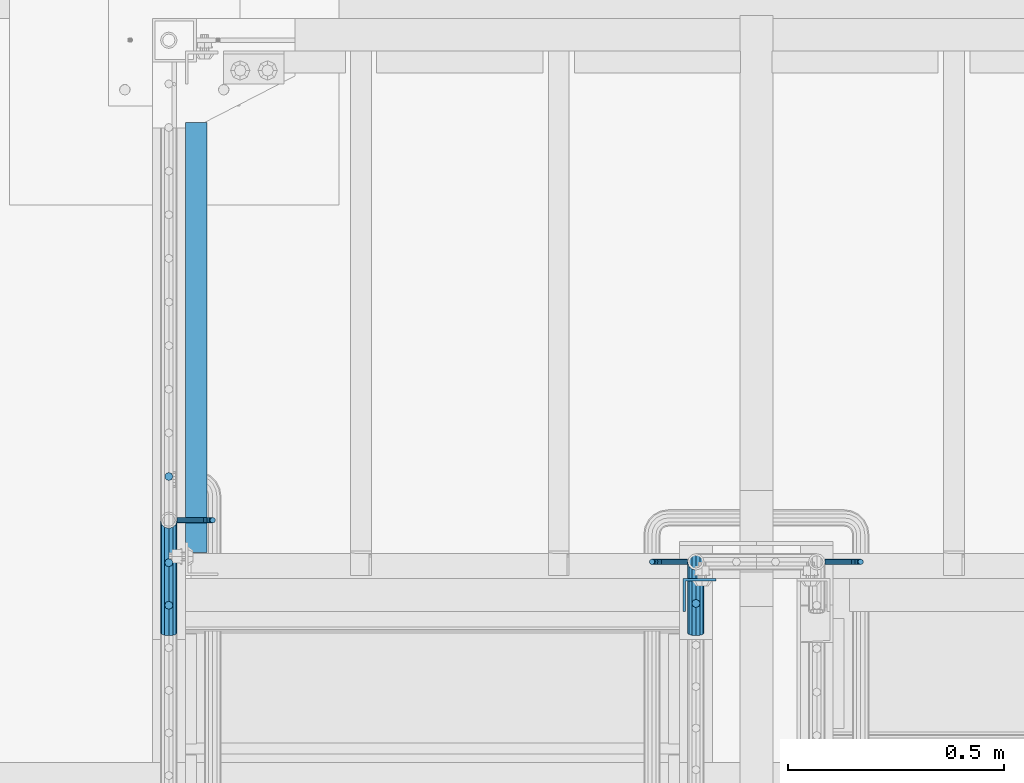
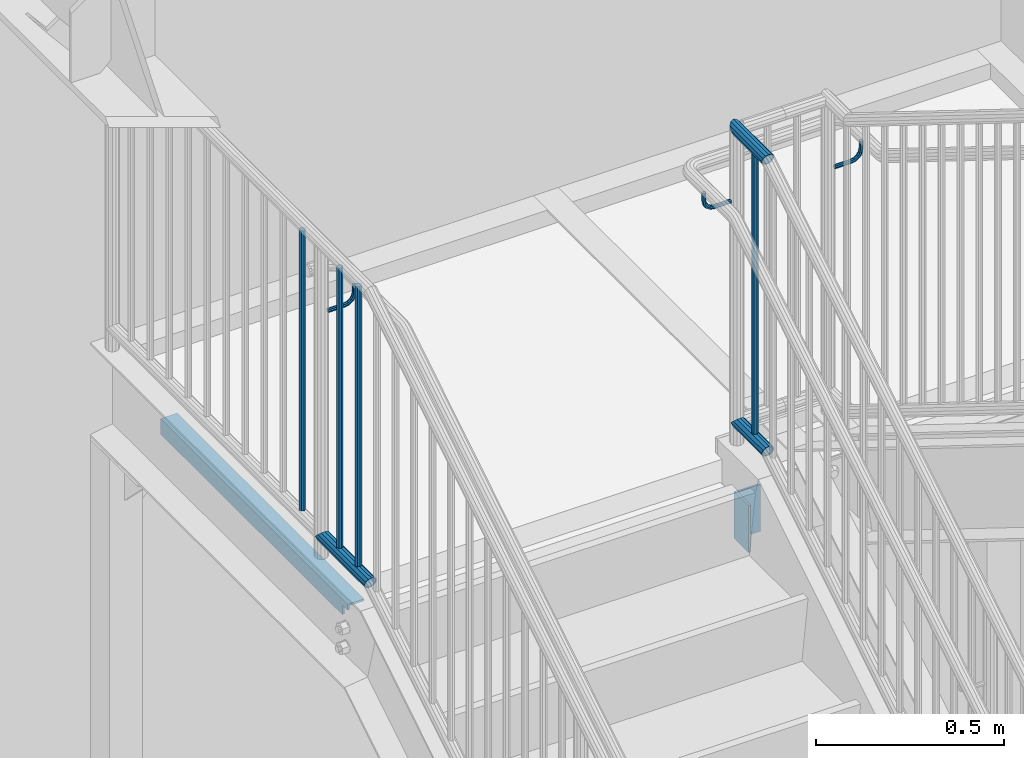
# One storey, part 1273 of 1763: 12 beams, 4 elements without a shape of their own.
"""IFC2X3 building model written with IfcOpenShell, lengths in millimetres."""

from ifc_helpers import new_model, si_unit, frame, origin_with_axes, place, context, subcontext, project, spatial, faceted_brep, material, type_object, element, aggregate, save


model = new_model("IFC2X3")

# Units and contexts
model_context = context("Model", 3, precision=1e-05, world=origin_with_axes())
body_context = subcontext(model_context, "Body", "Model", "MODEL_VIEW")
ifc_project = project(units=[si_unit("LENGTHUNIT", "METRE", prefix="MILLI"), si_unit("AREAUNIT", "SQUARE_METRE"), si_unit("VOLUMEUNIT", "CUBIC_METRE"), si_unit("MASSUNIT", "GRAM", prefix="KILO"), si_unit("TIMEUNIT", "SECOND"), si_unit("PLANEANGLEUNIT", "RADIAN"), si_unit("SOLIDANGLEUNIT", "STERADIAN"), si_unit("THERMODYNAMICTEMPERATUREUNIT", "DEGREE_CELSIUS"), si_unit("LUMINOUSINTENSITYUNIT", "LUMEN")], contexts=[model_context])

# Site, building, storey
site_placement = place(None, origin_with_axes())
site = spatial("IfcSite", under=ifc_project, at=site_placement, CompositionType="ELEMENT")
building_placement = place(site_placement, origin_with_axes())
building = spatial("IfcBuilding", under=site, at=building_placement, Name="Undefined", CompositionType="ELEMENT")
storey_placement = place(building_placement, origin_with_axes())
storey = spatial("IfcBuildingStorey", under=building, at=storey_placement, Name="Undefined", CompositionType="ELEMENT", Elevation=0.0)

# Assembly, beams
assembly_1_placement = place(storey_placement, origin_with_axes())
assembly_1 = element("IfcElementAssembly", 1, at=assembly_1_placement, inside=storey, Name="RAIL", AssemblyPlace="NOTDEFINED", PredefinedType="RIGID_FRAME")
ifc_material_1 = material(Name="STEEL/A513")
beam_type_1 = type_object("IfcBeamType", PredefinedType="NOTDEFINED")
beam_1_placement = place(assembly_1_placement, frame((-85559.3372736932, 35928.2999984601, 2852.7375000151), z_axis=(0.0, 0.0, 1.0), x_axis=(0.0, 1.0, 0.0)))
beam_1 = element("IfcBeam", 2, at=beam_1_placement, type_object=beam_type_1, material=ifc_material_1, Name="RAIL", context=body_context, shape_type="Brep", body=[
    faceted_brep([(148.602217967113, -9.52499999999418, 16.4977839420935), (148.602217967113, -9.52499999999418, 11.4667123799554), (148.108789529251, -7.68349999999919, 13.3082123799554), (146.050001909207, 0.0, 15.3670000000002), (146.050001909207, 0.0, 19.0500000000002), (148.108789529251, 7.68349999999919, 13.3082123799554), (148.602217967113, 9.52499999999418, 11.4667123799554), (148.602217967113, 9.52499999999418, 16.4977839420935), (165.10000190921, 19.0500000000029, 0.0), (155.575001909208, 16.4977839420899, 9.52500000000009), (155.575001909208, 16.4977839420899, -9.52500000000009), (152.385430347073, 13.3082123799541, 7.68350000000009), (154.444217967117, 15.3669999999984, 0.0), (152.385430347073, 13.3082123799541, -7.68350000000009), (148.602217967113, 9.52499999999418, -11.4667123799554), (148.602217967113, 9.52499999999418, -16.4977839420935), (148.108789529251, 7.68349999999919, -13.3082123799554), (146.050001909207, 0.0, -15.3670000000002), (146.050001909207, 0.0, -19.0500000000002), (148.602217967113, -9.52499999999418, -11.4667123799554), (148.602217967113, -9.52499999999418, -16.4977839420935), (148.108789529251, -7.68349999999919, -13.3082123799554), (165.10000190921, -19.0500000000029, 0.0), (155.575001909208, -16.4977839420899, -9.52500000000009), (155.575001909208, -16.4977839420899, 9.52500000000009), (152.385430347073, -13.3082123799541, -7.68350000000009), (154.444217967117, -15.3669999999984, 0.0), (152.385430347073, -13.3082123799541, 7.68350000000009), (2.71516178591992, -16.4977839420899, -9.52500000000009), (4.70279812946683, -9.52499999999418, -16.4977839420935), (5.43032352469163, 0.0, -19.0500000000002), (4.70279812946683, 9.52499999999418, -16.4977839420935), (2.71516178591992, 16.4977839420899, -9.52500000000009), (0.0, 19.0500000000029, 0.0), (-2.71516169163806, 16.4977839420899, 9.52500000000009), (-4.70279803518497, 9.52499999999418, 16.4977839420935), (-5.43032343040977, 0.0, 19.0500000000002), (-4.70279803518497, -9.52499999999418, 16.4977839420935), (-2.71516169163806, -16.4977839420899, 9.52500000000009), (0.0, -19.0500000000029, 0.0), (2.19023051641852, -13.3082123799541, -7.68350000000009), (3.79359050021594, -7.68349999999919, -13.3082123799554), (4.38046098569612, 0.0, -15.3670000000002), (3.79359050021594, 7.68349999999919, -13.3082123799554), (2.19023051641852, 13.3082123799541, -7.68350000000009), (4.71409293822944e-08, 15.3669999999984, 0.0), (-2.19023042213666, 13.3082123799541, 7.68350000000009), (-3.79359040593408, 7.68349999999919, 13.3082123799554), (-4.38046089142154, 0.0, 15.3670000000002), (-3.79359040593408, -7.68349999999919, 13.3082123799554), (-2.19023042213666, -13.3082123799541, 7.68350000000009), (4.71409293822944e-08, -15.3669999999984, 0.0)], [[[0, 1, 2, 3, 4]], [[4, 3, 5, 6, 7]], [[8, 9, 10]], [[7, 6, 11, 12, 13, 14, 15, 10, 9]], [[16, 17, 18, 15, 14]], [[19, 20, 18, 17, 21]], [[22, 23, 24]], [[24, 23, 20, 19, 25, 26, 27, 1, 0]], [[28, 29, 20, 23]], [[29, 30, 18, 20]], [[30, 31, 15, 18]], [[31, 32, 10, 15]], [[32, 33, 8, 10]], [[33, 34, 9, 8]], [[34, 35, 7, 9]], [[35, 36, 4, 7]], [[36, 37, 0, 4]], [[37, 38, 24, 0]], [[38, 39, 22, 24]], [[39, 28, 23, 22]], [[38, 37, 36, 35, 34, 33, 32, 31, 30, 29, 28, 39], [40, 41, 42, 43, 44, 45, 46, 47, 48, 49, 50, 51]], [[40, 51, 26, 25]], [[21, 41, 40, 25, 19]], [[42, 41, 21, 17]], [[43, 42, 17, 16]], [[44, 43, 16, 14, 13]], [[45, 44, 13, 12]], [[46, 45, 12, 11]], [[5, 47, 46, 11, 6]], [[48, 47, 5, 3]], [[49, 48, 3, 2]], [[50, 49, 2, 1, 27]], [[51, 50, 27, 26]]]),
])
beam_2_placement = place(assembly_1_placement, frame((-85559.3372736932, 36093.4000003693, 3798.8875000151), z_axis=(0.0, 0.0, -1.0), x_axis=(0.0, -1.0, 0.0)))
beam_2 = element("IfcBeam", 3, at=beam_2_placement, type_object=beam_type_1, material=ifc_material_1, Name="RAIL", context=body_context, shape_type="Brep", body=[
    faceted_brep([(4.71409293822944e-08, -15.3669999999984, 0.0), (7.68350000096689, -13.3082123799541, 7.68350000000009), (162.909771405139, -13.3082123799541, 7.68350000000009), (165.100001874416, -15.3669999999984, 0.0), (13.3082123809218, -7.68349999999919, 13.3082123799554), (161.306411421341, -7.68349999999919, 13.3082123799554), (15.3670000009661, 0.0, 15.3670000000002), (160.719540935861, 0.0, 15.3670000000002), (13.3082123809218, 7.68349999999919, 13.3082123799554), (161.306411421341, 7.68349999999919, 13.3082123799554), (7.68350000096689, 13.3082123799541, 7.68350000000009), (162.909771405139, 13.3082123799541, 7.68350000000009), (4.71409293822944e-08, 15.3669999999984, 0.0), (165.100001874416, 15.3669999999984, 0.0), (-7.68349999903876, 13.3082123799541, -7.68350000000009), (167.290232343701, 13.3082123799541, -7.68350000000009), (-13.3082123789936, 7.68349999999919, -13.3082123799554), (168.893592327498, 7.68349999999919, -13.3082123799554), (-15.3669999990379, 0.0, -15.3670000000002), (169.480462812979, 0.0, -15.3670000000002), (-13.3082123789936, -7.68349999999919, -13.3082123799554), (168.893592327498, -7.68349999999919, -13.3082123799554), (-7.68349999903876, -13.3082123799541, -7.68350000000009), (167.290232343701, -13.3082123799541, -7.68350000000009), (0.0, -19.0500000000029, 0.0), (-9.52499999903375, -16.4977839420899, -9.52500000000009), (167.815163613195, -16.4977839420899, -9.52500000000009), (165.10000190921, -19.0500000000029, 0.0), (-16.4977839411295, -9.52499999999418, -16.4977839420935), (169.802799956749, -9.52499999999418, -16.4977839420935), (-19.0499999990352, 0.0, -19.0500000000002), (170.530325351974, 0.0, -19.0500000000002), (-16.4977839411295, 9.52499999999418, -16.4977839420935), (169.802799956749, 9.52499999999418, -16.4977839420935), (-9.52499999903375, 16.4977839420899, -9.52500000000009), (167.815163613195, 16.4977839420899, -9.52500000000009), (0.0, 19.0500000000029, 0.0), (165.10000190921, 19.0500000000029, 0.0), (9.52500000096188, 16.4977839420899, 9.52500000000009), (162.384840135644, 16.4977839420899, 9.52500000000009), (16.4977839430576, 9.52499999999418, 16.4977839420935), (160.39720379209, 9.52499999999418, 16.4977839420935), (19.0500000009633, 0.0, 19.0500000000002), (159.669678396865, 0.0, 19.0500000000002), (16.4977839430576, -9.52499999999418, 16.4977839420935), (160.39720379209, -9.52499999999418, 16.4977839420935), (9.52500000096188, -16.4977839420899, 9.52500000000009), (162.384840135644, -16.4977839420899, 9.52500000000009)], [[[0, 1, 2, 3]], [[1, 4, 5, 2]], [[4, 6, 7, 5]], [[6, 8, 9, 7]], [[8, 10, 11, 9]], [[10, 12, 13, 11]], [[12, 14, 15, 13]], [[14, 16, 17, 15]], [[16, 18, 19, 17]], [[18, 20, 21, 19]], [[20, 22, 23, 21]], [[22, 0, 3, 23]], [[24, 25, 26, 27]], [[25, 28, 29, 26]], [[28, 30, 31, 29]], [[30, 32, 33, 31]], [[32, 34, 35, 33]], [[34, 36, 37, 35]], [[36, 38, 39, 37]], [[38, 40, 41, 39]], [[40, 42, 43, 41]], [[42, 44, 45, 43]], [[44, 46, 47, 45]], [[46, 24, 27, 47]], [[29, 31, 33, 35, 37, 39, 41, 43, 45, 47, 27, 26], [5, 7, 9, 11, 13, 15, 17, 19, 21, 23, 3, 2]], [[46, 44, 42, 40, 38, 36, 34, 32, 30, 28, 25, 24], [22, 20, 18, 16, 14, 12, 10, 8, 6, 4, 1, 0]]]),
])

# Assembly, beam
assembly_2_placement = place(storey_placement, origin_with_axes())
assembly_2 = element("IfcElementAssembly", 4, at=assembly_2_placement, inside=storey, Name="RAIL", AssemblyPlace="NOTDEFINED", PredefinedType="RIGID_FRAME")
beam_3_placement = place(assembly_2_placement, frame((-86778.5372736909, 35928.2999984695, 2852.7375000151), z_axis=(0.0, 0.0, 1.0), x_axis=(0.0, 1.0, 0.0)))
beam_3 = element("IfcBeam", 5, at=beam_3_placement, type_object=beam_type_1, material=ifc_material_1, Name="RAIL", context=body_context, shape_type="Brep", body=[
    faceted_brep([(245.122217953525, -9.52499999999418, 16.4977839420935), (245.122217953525, -9.52499999782594, 11.4667123821237), (244.628789516246, -7.68349999999919, 13.3082123799554), (242.570001895619, 0.0, 15.3670000000002), (242.570001895619, 0.0, 19.0500000000002), (244.628789515089, 7.68349999999919, 13.3082123799554), (245.122217953525, 9.52500000216241, 11.4667123777872), (245.122217953525, 9.52499999999418, 16.4977839420935), (261.620001894713, 19.0500000000029, 0.0), (252.095001895621, 16.4977839420899, 9.52500000000009), (252.095001895621, 16.4977839420899, -9.52500000000009), (248.905430331317, 13.3082123799541, 7.68350000000009), (250.964217951361, 15.3669999999984, 0.0), (248.905430331317, 13.3082123799541, -7.68350000000009), (245.122217953525, 9.52500000216241, -11.4667123777872), (245.122217953525, 9.52499999999418, -16.4977839420935), (244.628789515089, 7.68349999999919, -13.3082123799554), (242.570001895619, 0.0, -15.3670000000002), (242.570001895619, 0.0, -19.0500000000002), (245.122217953525, -9.52499999782594, -11.4667123821237), (245.122217953525, -9.52499999999418, -16.4977839420935), (244.628789516246, -7.68349999999919, -13.3082123799554), (261.620001895622, -19.0499999978347, 0.0), (252.095001895621, -16.4977839420899, -9.52500000000009), (252.095001895621, -16.4977839420899, 9.52500000000009), (248.905430335653, -13.3082123799541, -7.68350000000009), (250.964217955698, -15.3669999999984, 0.0), (248.905430335653, -13.3082123799541, 7.68350000000009), (2.71516178591992, -16.4977839420899, -9.52500000000009), (4.70279812946683, -9.52499999999418, -16.4977839420935), (5.43032352469163, 0.0, -19.0500000000002), (4.70279812946683, 9.52499999999418, -16.4977839420935), (2.71516178591992, 16.4977839420899, -9.52500000000009), (0.0, 19.0500000000029, 0.0), (-2.71516169163806, 16.4977839420899, 9.52500000000009), (-4.70279803518497, 9.52499999999418, 16.4977839420935), (-5.43032343040977, 0.0, 19.0500000000002), (-4.70279803518497, -9.52499999999418, 16.4977839420935), (-2.71516169163806, -16.4977839420899, 9.52500000000009), (0.0, -19.0500000000029, 0.0), (2.19023051641852, -13.3082123799541, -7.68350000000009), (3.79359050021594, -7.68349999999919, -13.3082123799554), (4.38046098569612, 0.0, -15.3670000000002), (3.79359050021594, 7.68349999999919, -13.3082123799554), (2.19023051641852, 13.3082123799541, -7.68350000000009), (4.71409293822944e-08, 15.3669999999984, 0.0), (-2.19023042213666, 13.3082123799541, 7.68350000000009), (-3.79359040593408, 7.68349999999919, 13.3082123799554), (-4.38046089142154, 0.0, 15.3670000000002), (-3.79359040593408, -7.68349999999919, 13.3082123799554), (-2.19023042213666, -13.3082123799541, 7.68350000000009), (4.71409293822944e-08, -15.3669999999984, 0.0)], [[[0, 1, 2, 3, 4]], [[4, 3, 5, 6, 7]], [[8, 9, 10]], [[7, 6, 11, 12, 13, 14, 15, 10, 9]], [[16, 17, 18, 15, 14]], [[19, 20, 18, 17, 21]], [[22, 23, 24]], [[24, 23, 20, 19, 25, 26, 27, 1, 0]], [[28, 29, 20, 23]], [[29, 30, 18, 20]], [[30, 31, 15, 18]], [[31, 32, 10, 15]], [[32, 33, 8, 10]], [[33, 34, 9, 8]], [[34, 35, 7, 9]], [[35, 36, 4, 7]], [[36, 37, 0, 4]], [[37, 38, 24, 0]], [[38, 39, 22, 24]], [[39, 28, 23, 22]], [[38, 37, 36, 35, 34, 33, 32, 31, 30, 29, 28, 39], [40, 41, 42, 43, 44, 45, 46, 47, 48, 49, 50, 51]], [[40, 51, 26, 25]], [[21, 41, 40, 25, 19]], [[42, 41, 21, 17]], [[43, 42, 17, 16]], [[44, 43, 16, 14, 13]], [[45, 44, 13, 12]], [[46, 45, 12, 11]], [[5, 47, 46, 11, 6]], [[48, 47, 5, 3]], [[49, 48, 3, 2]], [[50, 49, 2, 1, 27]], [[51, 50, 27, 26]]]),
])

assembly_3_placement = place(storey_placement, origin_with_axes())
assembly_3 = element("IfcElementAssembly", 6, at=assembly_3_placement, inside=storey, Name="STRINGER", AssemblyPlace="NOTDEFINED", PredefinedType="RIGID_FRAME")
ifc_material_2 = material(Name="STEEL/A36")
beam_type_2 = type_object("IfcBeamType", Name="L2X2X1/4", PredefinedType="NOTDEFINED")
beam_4_placement = place(assembly_3_placement, frame((-86715.0372737858, 37109.3996371524, 2630.48876467044), z_axis=(0.0, -1.42259999993257e-05, -0.99999999989881), x_axis=(0.0, -0.99999999989881, 1.42259999987655e-05)))
beam_4 = element("IfcBeam", 7, at=beam_4_placement, type_object=beam_type_2, material=ifc_material_2, Name="ANGLE", ObjectType="L2X2X1/4", context=body_context, shape_type="Brep", body=[
    faceted_brep([(965.199274753315, 19.0500000000029, 25.3999999999201), (965.199726428713, 19.0500000000029, -6.33500439582212), (965.199726428713, 25.3999999999942, -6.33500439582212), (965.199274753315, 25.3999999999942, 25.3999999999201), (993.774727188727, 19.0500000000029, -6.33459788777009), (993.798162603365, 25.3999999999942, -6.33459788777054), (-1.45519152283669e-11, -25.4000000000015, -25.3999999999869), (-7.27595761418343e-12, -25.4000000000015, -19.0499999999956), (-7.27595761418343e-12, 19.0499999999993, -19.0499999999956), (1.45519152283669e-11, 19.0499999999993, 25.3999999999796), (1.45519152283669e-11, 25.4000000000015, 25.3999999999796), (-1.45519152283669e-11, 25.4000000000015, -25.3999999999869), (993.798162603474, 25.3999999999942, -25.3999999999182), (993.798162603474, -25.3999999999942, -25.3999999999182), (993.798162603453, -25.3999999999942, -19.0499999999197), (993.798162603453, 19.0500000000029, -19.0499999999197)], [[[0, 1, 2, 3]], [[4, 5, 2, 1]], [[6, 7, 8, 9, 10, 11]], [[6, 11, 12, 13]], [[7, 6, 13, 14]], [[8, 7, 14, 15]], [[0, 9, 8, 15, 4, 1]], [[10, 9, 0, 3]], [[12, 11, 10, 3, 2, 5]], [[15, 14, 13, 12, 5, 4]]]),
])

# Beam
beam_type_3 = type_object("IfcBeamType", PredefinedType="NOTDEFINED")
beam_5_placement = place(assembly_2_placement, frame((-86759.4872736811, 36189.9200003692, 3570.28760005298), z_axis=(0.0, -1.0, 0.0), x_axis=(1.0, 0.0, 0.0)))
beam_5 = element("IfcBeam", 8, at=beam_5_placement, type_object=beam_type_3, material=ifc_material_2, Name="RAIL", context=body_context, shape_type="Brep", body=[
    faceted_brep([(0.0, -6.34999999999491, 1.45519152283669e-11), (-1.13686837721616e-13, -4.49012806053361, -4.49012806058454), (50.8000030517578, -4.49012806053452, -4.49012806053361), (50.8000030517578, -6.35000000000036, 0.0), (0.0, 0.0, -6.34999990463257), (50.8000030517578, 0.0, -6.34999999999854), (0.0, 4.49012806054088, -4.49012806053452), (50.8000030517578, 4.49012806053452, -4.49012806053361), (0.0, 6.34999999999491, -2.91038304567337e-11), (50.8000030517578, 6.35000000000036, 0.0), (0.0, 4.49012806054088, 4.49012806053452), (50.8000030517578, 4.49012806053452, 4.49012806053361), (0.0, 0.0, 6.34999990463257), (50.8000030517578, 0.0, 6.34999999999854), (0.0, -4.49012806053361, 4.49012806055543), (50.8000030517578, -4.49012806053452, 4.49012806053361), (65.380241824867, -3.44981018867929, 0.0), (64.6684996473195, -1.73151257071549, 4.49012806053361), (62.9502020293439, 2.4168248427668, 6.34999999999854), (61.2319044113829, 6.5651622562491, 4.49012806053361), (60.5201622338354, 8.2834598742138, 0.0), (61.2319044113829, 6.5651622562491, -4.49012806053361), (62.9502020293439, 2.4168248427668, -6.34999999999854), (64.6684996473195, -1.73151257071549, -4.49012806053361), (76.425643354436, 6.12435969732724, -4.49012806053361), (77.7407714149595, 4.8092316367929, 0.0), (73.2506433544331, 9.29935969732742, -6.34999999999854), (70.0756433544302, 12.4743596973276, -4.49012806053361), (68.7605152938922, 13.7894877578619, 0.0), (70.0756433544302, 12.4743596973276, 4.49012806053361), (73.2506433544331, 9.29935969732742, 6.34999999999854), (76.425643354436, 6.12435969732724, 4.49012806053361), (84.2815156224679, 17.8815034044446, -4.49012806053361), (85.9998132404435, 17.1697612268908, 0.0), (80.1331782089983, 19.5998010224093, -6.34999999999854), (75.9848407955142, 21.3180986403731, -4.49012806053361), (74.2665431775386, 22.0298408179269, 0.0), (75.9848407955142, 21.3180986403731, 4.49012806053361), (80.1331782089983, 19.5998010224093, 6.34999999999854), (84.2815156224679, 17.8815034044446, 4.49012806053361), (87.0401311122987, 31.75, -4.49012806053361), (88.9000030517636, 31.75, 0.0), (82.5500030517578, 31.75, -6.34999999999854), (78.0598749912169, 31.75, -4.49012806053361), (76.200003051752, 31.75, 0.0), (78.0598749912169, 31.75, 4.49012806053361), (82.5500030517578, 31.75, 6.34999999999854), (87.0401311122987, 31.75, 4.49012806053361), (87.0401311122987, 57.1500015258789, -4.49012806053361), (88.9000030517636, 57.1500015258789, 0.0), (82.5500030517578, 57.1500015258789, -6.34999999999854), (78.0598749912169, 57.1500015258789, -4.49012806053361), (76.200003051752, 57.1500015258789, 0.0), (78.0598749912169, 57.1500015258789, 4.49012806053361), (82.5500030517578, 57.1500015258789, 6.34999999999854), (87.0401311122987, 57.1500015258789, 4.49012806053361)], [[[0, 1, 2, 3]], [[1, 4, 5, 2]], [[4, 6, 7, 5]], [[6, 8, 9, 7]], [[8, 10, 11, 9]], [[10, 12, 13, 11]], [[12, 14, 15, 13]], [[14, 0, 3, 15]], [[14, 12, 10, 8, 6, 4, 1, 0]], [[15, 3, 16, 17]], [[13, 15, 17, 18]], [[11, 13, 18, 19]], [[9, 11, 19, 20]], [[7, 9, 20, 21]], [[5, 7, 21, 22]], [[2, 5, 22, 23]], [[3, 2, 23, 16]], [[23, 24, 25, 16]], [[22, 26, 24, 23]], [[21, 27, 26, 22]], [[20, 28, 27, 21]], [[19, 29, 28, 20]], [[18, 30, 29, 19]], [[17, 31, 30, 18]], [[16, 25, 31, 17]], [[24, 32, 33, 25]], [[26, 34, 32, 24]], [[27, 35, 34, 26]], [[28, 36, 35, 27]], [[29, 37, 36, 28]], [[30, 38, 37, 29]], [[31, 39, 38, 30]], [[25, 33, 39, 31]], [[32, 40, 41, 33]], [[34, 42, 40, 32]], [[35, 43, 42, 34]], [[36, 44, 43, 35]], [[37, 45, 44, 36]], [[38, 46, 45, 37]], [[39, 47, 46, 38]], [[33, 41, 47, 39]], [[41, 40, 48, 49]], [[40, 42, 50, 48]], [[42, 43, 51, 50]], [[43, 44, 52, 51]], [[44, 45, 53, 52]], [[45, 46, 54, 53]], [[46, 47, 55, 54]], [[47, 41, 49, 55]], [[50, 51, 52, 53, 54, 55, 49, 48]]]),
])

# Assembly, beam
assembly_4_placement = place(storey_placement, origin_with_axes())
assembly_4 = element("IfcElementAssembly", 9, at=assembly_4_placement, inside=storey, Name="RAIL", AssemblyPlace="NOTDEFINED", PredefinedType="RIGID_FRAME")
beam_6_placement = place(assembly_4_placement, frame((-85260.8221005486, 36093.4000003674, 3570.28759880967), z_axis=(0.0, -1.0, 0.0), x_axis=(1.0, 0.0, 0.0)))
beam_6 = element("IfcBeam", 10, at=beam_6_placement, type_object=beam_type_3, material=ifc_material_2, Name="RAIL", context=body_context, shape_type="Brep", body=[
    faceted_brep([(0.0, -6.34999999999491, 1.45519152283669e-11), (-1.13686837721616e-13, -4.49012806053361, -4.49012806058454), (50.8000030517578, -4.49012806053452, -4.49012806053361), (50.8000030517578, -6.35000000000036, 0.0), (0.0, 0.0, -6.34999990463257), (50.8000030517578, 0.0, -6.34999999999854), (0.0, 4.49012806054088, -4.49012806053452), (50.8000030517578, 4.49012806053452, -4.49012806053361), (0.0, 6.34999999999491, -2.91038304567337e-11), (50.8000030517578, 6.35000000000036, 0.0), (0.0, 4.49012806054088, 4.49012806053452), (50.8000030517578, 4.49012806053452, 4.49012806053361), (0.0, 0.0, 6.34999990463257), (50.8000030517578, 0.0, 6.34999999999854), (0.0, -4.49012806053361, 4.49012806055543), (50.8000030517578, -4.49012806053452, 4.49012806053361), (65.380241824867, -3.44981018867929, 0.0), (64.6684996473195, -1.73151257071549, 4.49012806053361), (62.9502020293439, 2.4168248427668, 6.34999999999854), (61.2319044113829, 6.5651622562491, 4.49012806053361), (60.5201622338354, 8.2834598742138, 0.0), (61.2319044113829, 6.5651622562491, -4.49012806053361), (62.9502020293439, 2.4168248427668, -6.34999999999854), (64.6684996473195, -1.73151257071549, -4.49012806053361), (76.425643354436, 6.12435969732724, -4.49012806053361), (77.7407714149595, 4.8092316367929, 0.0), (73.2506433544331, 9.29935969732742, -6.34999999999854), (70.0756433544302, 12.4743596973276, -4.49012806053361), (68.7605152938922, 13.7894877578619, 0.0), (70.0756433544302, 12.4743596973276, 4.49012806053361), (73.2506433544331, 9.29935969732742, 6.34999999999854), (76.425643354436, 6.12435969732724, 4.49012806053361), (84.2815156224679, 17.8815034044446, -4.49012806053361), (85.9998132404435, 17.1697612268908, 0.0), (80.1331782089983, 19.5998010224093, -6.34999999999854), (75.9848407955142, 21.3180986403731, -4.49012806053361), (74.2665431775386, 22.0298408179269, 0.0), (75.9848407955142, 21.3180986403731, 4.49012806053361), (80.1331782089983, 19.5998010224093, 6.34999999999854), (84.2815156224679, 17.8815034044446, 4.49012806053361), (87.0401311122987, 31.75, -4.49012806053361), (88.9000030517636, 31.75, 0.0), (82.5500030517578, 31.75, -6.34999999999854), (78.0598749912169, 31.75, -4.49012806053361), (76.200003051752, 31.75, 0.0), (78.0598749912169, 31.75, 4.49012806053361), (82.5500030517578, 31.75, 6.34999999999854), (87.0401311122987, 31.75, 4.49012806053361), (87.0401311122987, 57.1500015258789, -4.49012806053361), (88.9000030517636, 57.1500015258789, 0.0), (82.5500030517578, 57.1500015258789, -6.34999999999854), (78.0598749912169, 57.1500015258789, -4.49012806053361), (76.200003051752, 57.1500015258789, 0.0), (78.0598749912169, 57.1500015258789, 4.49012806053361), (82.5500030517578, 57.1500015258789, 6.34999999999854), (87.0401311122987, 57.1500015258789, 4.49012806053361)], [[[0, 1, 2, 3]], [[1, 4, 5, 2]], [[4, 6, 7, 5]], [[6, 8, 9, 7]], [[8, 10, 11, 9]], [[10, 12, 13, 11]], [[12, 14, 15, 13]], [[14, 0, 3, 15]], [[14, 12, 10, 8, 6, 4, 1, 0]], [[15, 3, 16, 17]], [[13, 15, 17, 18]], [[11, 13, 18, 19]], [[9, 11, 19, 20]], [[7, 9, 20, 21]], [[5, 7, 21, 22]], [[2, 5, 22, 23]], [[3, 2, 23, 16]], [[23, 24, 25, 16]], [[22, 26, 24, 23]], [[21, 27, 26, 22]], [[20, 28, 27, 21]], [[19, 29, 28, 20]], [[18, 30, 29, 19]], [[17, 31, 30, 18]], [[16, 25, 31, 17]], [[24, 32, 33, 25]], [[26, 34, 32, 24]], [[27, 35, 34, 26]], [[28, 36, 35, 27]], [[29, 37, 36, 28]], [[30, 38, 37, 29]], [[31, 39, 38, 30]], [[25, 33, 39, 31]], [[32, 40, 41, 33]], [[34, 42, 40, 32]], [[35, 43, 42, 34]], [[36, 44, 43, 35]], [[37, 45, 44, 36]], [[38, 46, 45, 37]], [[39, 47, 46, 38]], [[33, 41, 47, 39]], [[41, 40, 48, 49]], [[40, 42, 50, 48]], [[42, 43, 51, 50]], [[43, 44, 52, 51]], [[44, 45, 53, 52]], [[45, 46, 54, 53]], [[46, 47, 55, 54]], [[47, 41, 49, 55]], [[50, 51, 52, 53, 54, 55, 49, 48]]]),
])
aggregate(assembly_4, [beam_6])

# Beam
beam_7_placement = place(assembly_1_placement, frame((-85578.3872739632, 36093.4000003674, 3570.28759880967), z_axis=(0.0, 1.0, 0.0), x_axis=(-1.0, 0.0, 0.0)))
beam_7 = element("IfcBeam", 11, at=beam_7_placement, type_object=beam_type_3, material=ifc_material_2, Name="RAIL", context=body_context, shape_type="Brep", body=[
    faceted_brep([(0.0, -6.34999999999491, 1.45519152283669e-11), (-1.13686837721616e-13, -4.49012806053361, -4.49012806058454), (50.8000030517578, -4.49012806053452, -4.49012806053361), (50.8000030517578, -6.35000000000036, 0.0), (0.0, 0.0, -6.34999990463257), (50.8000030517578, 0.0, -6.34999999999854), (0.0, 4.49012806054088, -4.49012806053452), (50.8000030517578, 4.49012806053452, -4.49012806053361), (0.0, 6.34999999999491, -2.91038304567337e-11), (50.8000030517578, 6.35000000000036, 0.0), (0.0, 4.49012806054088, 4.49012806053452), (50.8000030517578, 4.49012806053452, 4.49012806053361), (0.0, 0.0, 6.34999990463257), (50.8000030517578, 0.0, 6.34999999999854), (0.0, -4.49012806053361, 4.49012806055543), (50.8000030517578, -4.49012806053452, 4.49012806053361), (65.380241824867, -3.44981018867929, 0.0), (64.6684996473195, -1.73151257071549, 4.49012806053361), (62.9502020293439, 2.4168248427668, 6.34999999999854), (61.2319044113829, 6.5651622562491, 4.49012806053361), (60.5201622338354, 8.2834598742138, 0.0), (61.2319044113829, 6.5651622562491, -4.49012806053361), (62.9502020293439, 2.4168248427668, -6.34999999999854), (64.6684996473195, -1.73151257071549, -4.49012806053361), (76.425643354436, 6.12435969732724, -4.49012806053361), (77.7407714149595, 4.8092316367929, 0.0), (73.2506433544331, 9.29935969732742, -6.34999999999854), (70.0756433544302, 12.4743596973276, -4.49012806053361), (68.7605152938922, 13.7894877578619, 0.0), (70.0756433544302, 12.4743596973276, 4.49012806053361), (73.2506433544331, 9.29935969732742, 6.34999999999854), (76.425643354436, 6.12435969732724, 4.49012806053361), (84.2815156224679, 17.8815034044446, -4.49012806053361), (85.9998132404435, 17.1697612268908, 0.0), (80.1331782089983, 19.5998010224093, -6.34999999999854), (75.9848407955142, 21.3180986403731, -4.49012806053361), (74.2665431775386, 22.0298408179269, 0.0), (75.9848407955142, 21.3180986403731, 4.49012806053361), (80.1331782089983, 19.5998010224093, 6.34999999999854), (84.2815156224679, 17.8815034044446, 4.49012806053361), (87.0401311122987, 31.75, -4.49012806053361), (88.9000030517636, 31.75, 0.0), (82.5500030517578, 31.75, -6.34999999999854), (78.0598749912169, 31.75, -4.49012806053361), (76.200003051752, 31.75, 0.0), (78.0598749912169, 31.75, 4.49012806053361), (82.5500030517578, 31.75, 6.34999999999854), (87.0401311122987, 31.75, 4.49012806053361), (87.0401311122987, 57.1500015258789, -4.49012806053361), (88.9000030517636, 57.1500015258789, 0.0), (82.5500030517578, 57.1500015258789, -6.34999999999854), (78.0598749912169, 57.1500015258789, -4.49012806053361), (76.200003051752, 57.1500015258789, 0.0), (78.0598749912169, 57.1500015258789, 4.49012806053361), (82.5500030517578, 57.1500015258789, 6.34999999999854), (87.0401311122987, 57.1500015258789, 4.49012806053361)], [[[0, 1, 2, 3]], [[1, 4, 5, 2]], [[4, 6, 7, 5]], [[6, 8, 9, 7]], [[8, 10, 11, 9]], [[10, 12, 13, 11]], [[12, 14, 15, 13]], [[14, 0, 3, 15]], [[14, 12, 10, 8, 6, 4, 1, 0]], [[15, 3, 16, 17]], [[13, 15, 17, 18]], [[11, 13, 18, 19]], [[9, 11, 19, 20]], [[7, 9, 20, 21]], [[5, 7, 21, 22]], [[2, 5, 22, 23]], [[3, 2, 23, 16]], [[23, 24, 25, 16]], [[22, 26, 24, 23]], [[21, 27, 26, 22]], [[20, 28, 27, 21]], [[19, 29, 28, 20]], [[18, 30, 29, 19]], [[17, 31, 30, 18]], [[16, 25, 31, 17]], [[24, 32, 33, 25]], [[26, 34, 32, 24]], [[27, 35, 34, 26]], [[28, 36, 35, 27]], [[29, 37, 36, 28]], [[30, 38, 37, 29]], [[31, 39, 38, 30]], [[25, 33, 39, 31]], [[32, 40, 41, 33]], [[34, 42, 40, 32]], [[35, 43, 42, 34]], [[36, 44, 43, 35]], [[37, 45, 44, 36]], [[38, 46, 45, 37]], [[39, 47, 46, 38]], [[33, 41, 47, 39]], [[41, 40, 48, 49]], [[40, 42, 50, 48]], [[42, 43, 51, 50]], [[43, 44, 52, 51]], [[44, 45, 53, 52]], [[45, 46, 54, 53]], [[46, 47, 55, 54]], [[47, 41, 49, 55]], [[50, 51, 52, 53, 54, 55, 49, 48]]]),
])

beam_type_4 = type_object("IfcBeamType", PredefinedType="NOTDEFINED")
beam_8_placement = place(assembly_1_placement, frame((-85559.3372736932, 35997.2428575123, 3798.8875000151), z_axis=(-1.0, 0.0, 0.0), x_axis=(0.0, 0.0, -1.0)))
beam_8 = element("IfcBeam", 12, at=beam_8_placement, type_object=beam_type_4, material=ifc_material_2, Name="PICKET", context=body_context, shape_type="Brep", body=[
    faceted_brep([(19.0499999999092, -9.52500000000146, 0.0), (19.0499999999092, -6.73519209080405, -6.73519209079677), (927.099999996084, -6.73519209080405, -6.73519209079677), (927.099999996084, -9.52500000000146, 0.0), (19.0499999999092, 0.0, -9.52499999999418), (927.099999996084, 0.0, -9.52499999999418), (19.0499999999092, 6.73519209080405, -6.73519209079677), (927.099999996084, 6.73519209080405, -6.73519209079677), (19.0499999999092, 9.52500000000146, 0.0), (927.099999996084, 9.52500000000146, 0.0), (19.0499999999092, 6.73519209080405, 6.73519209079677), (927.099999996084, 6.73519209080405, 6.73519209079677), (19.0499999999092, 0.0, 9.52499999999418), (927.099999996084, 0.0, 9.52499999999418), (19.0499999999092, -6.73519209080405, 6.73519209079677), (927.099999996084, -6.73519209080405, 6.73519209079677)], [[[0, 1, 2, 3]], [[1, 4, 5, 2]], [[4, 6, 7, 5]], [[6, 8, 9, 7]], [[8, 10, 11, 9]], [[10, 12, 13, 11]], [[12, 14, 15, 13]], [[14, 0, 3, 15]], [[5, 7, 9, 11, 13, 15, 3, 2]], [[14, 12, 10, 8, 6, 4, 1, 0]]]),
])

aggregate(assembly_1, [beam_8, beam_1, beam_2, beam_7])

beam_9_placement = place(assembly_2_placement, frame((-86778.5372736927, 36290.8272730966, 3798.8875000151), z_axis=(-1.0, 0.0, 0.0), x_axis=(0.0, 0.0, -1.0)))
beam_9 = element("IfcBeam", 13, at=beam_9_placement, type_object=beam_type_4, material=ifc_material_2, Name="PICKET", context=body_context, shape_type="Brep", body=[
    faceted_brep([(19.0499999999092, -9.52500000000146, 0.0), (19.0499999999092, -6.73519209080405, -6.73519209079677), (927.099999996084, -6.73519209080405, -6.73519209079677), (927.099999996084, -9.52500000000146, 0.0), (19.0499999999092, 0.0, -9.52499999999418), (927.099999996084, 0.0, -9.52499999999418), (19.0499999999092, 6.73519209080405, -6.73519209079677), (927.099999996084, 6.73519209080405, -6.73519209079677), (19.0499999999092, 9.52500000000146, 0.0), (927.099999996084, 9.52500000000146, 0.0), (19.0499999999092, 6.73519209080405, 6.73519209079677), (927.099999996084, 6.73519209080405, 6.73519209079677), (19.0499999999092, 0.0, 9.52499999999418), (927.099999996084, 0.0, 9.52499999999418), (19.0499999999092, -6.73519209080405, 6.73519209079677), (927.099999996084, -6.73519209080405, 6.73519209079677)], [[[0, 1, 2, 3]], [[1, 4, 5, 2]], [[4, 6, 7, 5]], [[6, 8, 9, 7]], [[8, 10, 11, 9]], [[10, 12, 13, 11]], [[12, 14, 15, 13]], [[14, 0, 3, 15]], [[5, 7, 9, 11, 13, 15, 3, 2]], [[14, 12, 10, 8, 6, 4, 1, 0]]]),
])

beam_10_placement = place(assembly_2_placement, frame((-86778.5372736927, 36091.4647622741, 3798.8875000151), z_axis=(-1.0, 0.0, 0.0), x_axis=(0.0, 0.0, -1.0)))
beam_10 = element("IfcBeam", 14, at=beam_10_placement, type_object=beam_type_4, material=ifc_material_2, Name="PICKET", context=body_context, shape_type="Brep", body=[
    faceted_brep([(19.0499999999092, -9.52500000000146, 0.0), (19.0499999999092, -6.73519209080405, -6.73519209079677), (927.099999996084, -6.73519209080405, -6.73519209079677), (927.099999996084, -9.52500000000146, 0.0), (19.0499999999092, 0.0, -9.52499999999418), (927.099999996084, 0.0, -9.52499999999418), (19.0499999999092, 6.73519209080405, -6.73519209079677), (927.099999996084, 6.73519209080405, -6.73519209079677), (19.0499999999092, 9.52500000000146, 0.0), (927.099999996084, 9.52500000000146, 0.0), (19.0499999999092, 6.73519209080405, 6.73519209079677), (927.099999996084, 6.73519209080405, 6.73519209079677), (19.0499999999092, 0.0, 9.52499999999418), (927.099999996084, 0.0, 9.52499999999418), (19.0499999999092, -6.73519209080405, 6.73519209079677), (927.099999996084, -6.73519209080405, 6.73519209079677)], [[[0, 1, 2, 3]], [[1, 4, 5, 2]], [[4, 6, 7, 5]], [[6, 8, 9, 7]], [[8, 10, 11, 9]], [[10, 12, 13, 11]], [[12, 14, 15, 13]], [[14, 0, 3, 15]], [[5, 7, 9, 11, 13, 15, 3, 2]], [[14, 12, 10, 8, 6, 4, 1, 0]]]),
])

beam_11_placement = place(assembly_2_placement, frame((-86778.5372736927, 35993.0095241788, 3798.8875000151), z_axis=(-1.0, 0.0, 0.0), x_axis=(0.0, 0.0, -1.0)))
beam_11 = element("IfcBeam", 15, at=beam_11_placement, type_object=beam_type_4, material=ifc_material_2, Name="PICKET", context=body_context, shape_type="Brep", body=[
    faceted_brep([(19.0499999999092, -9.52500000000146, 0.0), (19.0499999999092, -6.73519209080405, -6.73519209079677), (927.099999996084, -6.73519209080405, -6.73519209079677), (927.099999996084, -9.52500000000146, 0.0), (19.0499999999092, 0.0, -9.52499999999418), (927.099999996084, 0.0, -9.52499999999418), (19.0499999999092, 6.73519209080405, -6.73519209079677), (927.099999996084, 6.73519209080405, -6.73519209079677), (19.0499999999092, 9.52500000000146, 0.0), (927.099999996084, 9.52500000000146, 0.0), (19.0499999999092, 6.73519209080405, 6.73519209079677), (927.099999996084, 6.73519209080405, 6.73519209079677), (19.0499999999092, 0.0, 9.52499999999418), (927.099999996084, 0.0, 9.52499999999418), (19.0499999999092, -6.73519209080405, 6.73519209079677), (927.099999996084, -6.73519209080405, 6.73519209079677)], [[[0, 1, 2, 3]], [[1, 4, 5, 2]], [[4, 6, 7, 5]], [[6, 8, 9, 7]], [[8, 10, 11, 9]], [[10, 12, 13, 11]], [[12, 14, 15, 13]], [[14, 0, 3, 15]], [[5, 7, 9, 11, 13, 15, 3, 2]], [[14, 12, 10, 8, 6, 4, 1, 0]]]),
])

aggregate(assembly_2, [beam_9, beam_10, beam_11, beam_3, beam_5])

beam_type_5 = type_object("IfcBeamType", Name="L3X3X1/4", PredefinedType="NOTDEFINED")
beam_12_placement = place(assembly_3_placement, frame((-85551.3997737272, 36017.1999996304, 2655.8875), z_axis=(1.0, 0.0, 0.0), x_axis=(0.0, 0.0, -1.0)))
beam_12 = element("IfcBeam", 16, at=beam_12_placement, type_object=beam_type_5, material=ifc_material_2, Name="ANGLE", ObjectType="L3X3X1/4", context=body_context, shape_type="Brep", body=[
    faceted_brep([(0.0, 38.0999999999985, -38.1000000000004), (0.0, 38.0999999999985, 38.1000000000004), (152.400006103515, 38.0999999999985, 38.1000000000058), (152.400006103515, 38.0999999999985, -38.1000000000058), (0.0, 31.75, 38.1000000000058), (152.400006103515, 31.75, 38.1000000000058), (0.0, 31.75, -31.75), (152.400006103515, 31.75, -31.75), (0.0, -38.1000000000004, -31.75), (152.400006103515, -38.0999999999985, -31.75), (0.0, -38.0999999999985, -38.1000000000004), (152.400006103515, -38.0999999999985, -38.1000000000058)], [[[0, 1, 2, 3]], [[1, 4, 5, 2]], [[4, 6, 7, 5]], [[6, 8, 9, 7]], [[8, 10, 11, 9]], [[10, 0, 3, 11]], [[5, 7, 9, 11, 3, 2]], [[10, 8, 6, 4, 1, 0]]]),
])

aggregate(assembly_3, [beam_12, beam_4])

save(model, "model.ifc")
